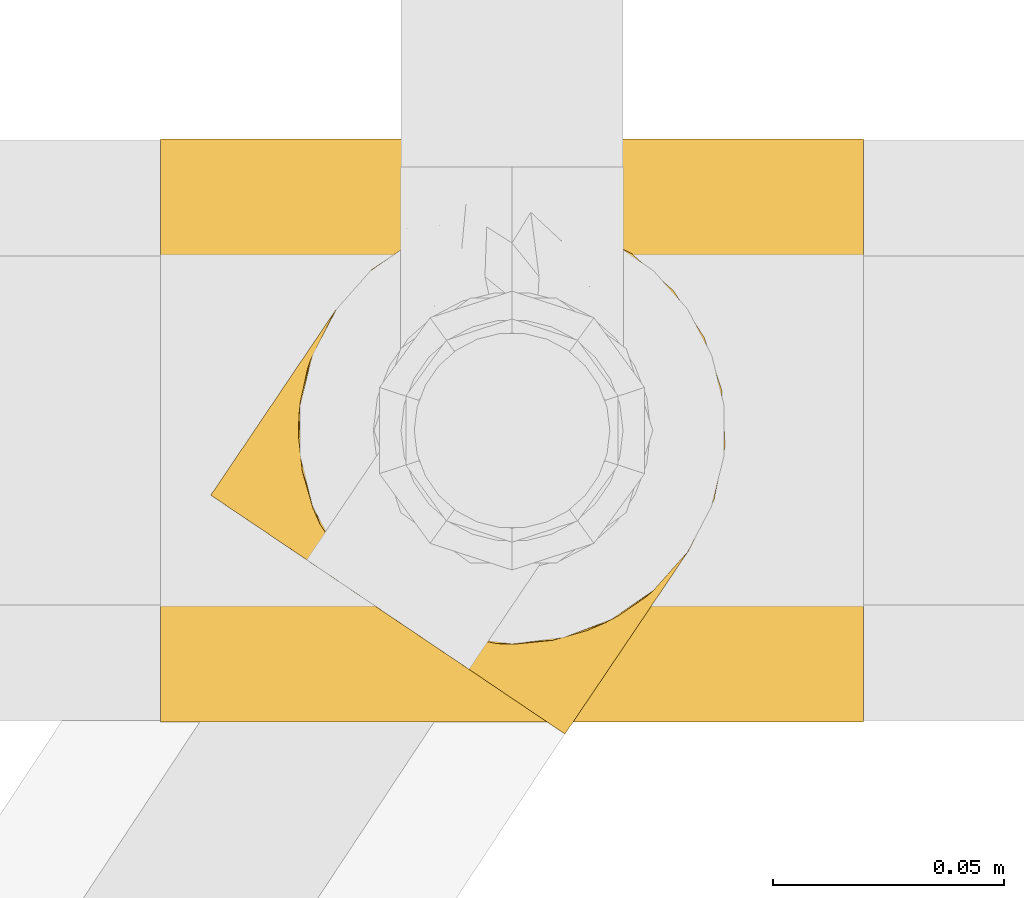
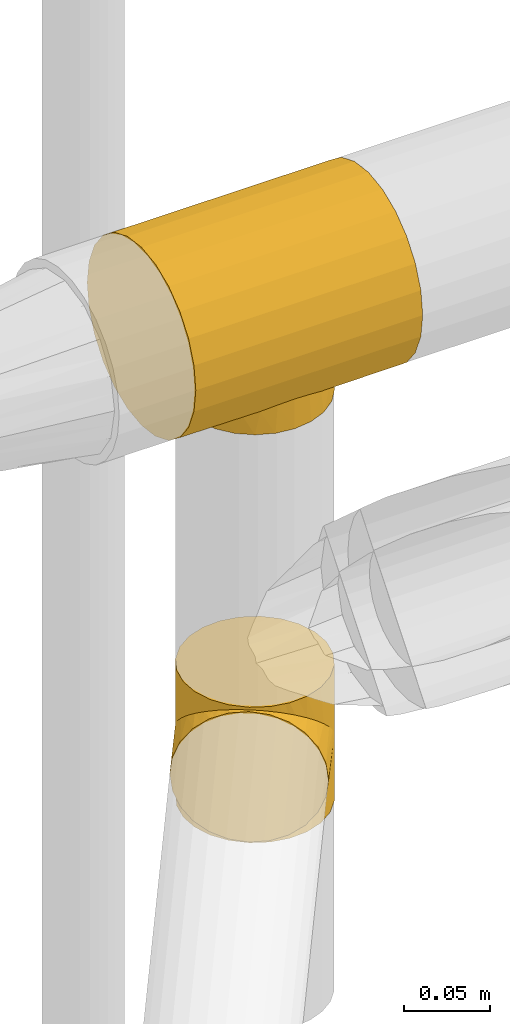
# One storey, part 390 of 827: 2 coverings.
"""IFC2X3 building model written with IfcOpenShell, lengths in millimetres."""

from ifc_helpers import new_model, entity, si_unit, converted_unit, derived_unit, direction, frame, origin, place, context, subcontext, project, spatial, faceted_brep, element, save


model = new_model("IFC2X3")

# Units and contexts
model_context = context("Model", 3, precision=0.01, world=origin(), true_north=direction((6.12303176911189e-17, 1.0)))
body_context = subcontext(model_context, "Body", "Model", "MODEL_VIEW")
ifc_project = project(units=[si_unit("LENGTHUNIT", "METRE", prefix="MILLI"), si_unit("AREAUNIT", "SQUARE_METRE"), si_unit("VOLUMEUNIT", "CUBIC_METRE"), converted_unit("PLANEANGLEUNIT", "DEGREE", entity("IfcRatioMeasure", 0.0174532925199433), si_unit("PLANEANGLEUNIT", "RADIAN"), dimensions=[0, 0, 0, 0, 0, 0, 0]), si_unit("MASSUNIT", "GRAM", prefix="KILO"), derived_unit("MASSDENSITYUNIT", [(si_unit("MASSUNIT", "GRAM", prefix="KILO"), 1), (si_unit("LENGTHUNIT", "METRE"), -3)]), derived_unit("MOMENTOFINERTIAUNIT", [(si_unit("LENGTHUNIT", "METRE"), 4)]), si_unit("TIMEUNIT", "SECOND"), si_unit("FREQUENCYUNIT", "HERTZ"), si_unit("THERMODYNAMICTEMPERATUREUNIT", "DEGREE_CELSIUS"), derived_unit("THERMALTRANSMITTANCEUNIT", [(si_unit("MASSUNIT", "GRAM", prefix="KILO"), 1), (si_unit("THERMODYNAMICTEMPERATUREUNIT", "KELVIN"), -1), (si_unit("TIMEUNIT", "SECOND"), -3)]), derived_unit("VOLUMETRICFLOWRATEUNIT", [(si_unit("LENGTHUNIT", "METRE"), 3), (si_unit("TIMEUNIT", "SECOND"), -1)]), derived_unit("MASSFLOWRATEUNIT", [(si_unit("MASSUNIT", "GRAM", prefix="KILO"), 1), (si_unit("TIMEUNIT", "SECOND"), -1)]), derived_unit("ROTATIONALFREQUENCYUNIT", [(si_unit("TIMEUNIT", "SECOND"), -1)]), si_unit("ELECTRICCURRENTUNIT", "AMPERE"), si_unit("ELECTRICVOLTAGEUNIT", "VOLT"), si_unit("POWERUNIT", "WATT"), si_unit("FORCEUNIT", "NEWTON", prefix="KILO"), si_unit("ILLUMINANCEUNIT", "LUX"), si_unit("LUMINOUSFLUXUNIT", "LUMEN"), si_unit("LUMINOUSINTENSITYUNIT", "CANDELA"), derived_unit("USERDEFINED", [(si_unit("MASSUNIT", "GRAM", prefix="KILO"), -1), (si_unit("LENGTHUNIT", "METRE"), -2), (si_unit("TIMEUNIT", "SECOND"), 3), (si_unit("LUMINOUSFLUXUNIT", "LUMEN"), 1)]), derived_unit("LINEARVELOCITYUNIT", [(si_unit("LENGTHUNIT", "METRE"), 1), (si_unit("TIMEUNIT", "SECOND"), -1)]), si_unit("PRESSUREUNIT", "PASCAL"), derived_unit("USERDEFINED", [(si_unit("LENGTHUNIT", "METRE"), -2), (si_unit("MASSUNIT", "GRAM", prefix="KILO"), 1), (si_unit("TIMEUNIT", "SECOND"), -2)]), derived_unit("LINEARFORCEUNIT", [(si_unit("MASSUNIT", "GRAM", prefix="KILO"), 1), (si_unit("LENGTHUNIT", "METRE"), 1), (si_unit("TIMEUNIT", "SECOND"), -2), (si_unit("LENGTHUNIT", "METRE"), -1)]), derived_unit("PLANARFORCEUNIT", [(si_unit("MASSUNIT", "GRAM", prefix="KILO"), 1), (si_unit("LENGTHUNIT", "METRE"), 1), (si_unit("TIMEUNIT", "SECOND"), -2), (si_unit("LENGTHUNIT", "METRE"), -2)])], contexts=[model_context])

# Site, building, storey
site_placement = place(None, origin())
site = spatial("IfcSite", under=ifc_project, at=site_placement, CompositionType="ELEMENT")
building_placement = place(site_placement, origin())
building = spatial("IfcBuilding", under=site, at=building_placement, CompositionType="ELEMENT")
storey_placement = place(building_placement, frame((0.0, 0.0, 28200.0)))
storey = spatial("IfcBuildingStorey", under=building, at=storey_placement, Name="08", CompositionType="ELEMENT", Elevation=28200.0)

# Coverings
covering_1_placement = place(storey_placement, frame((48216.02, 14171.03, 2540.35)))
element("IfcCovering", 1, at=covering_1_placement, inside=storey, Name=":ADSK_", ObjectType=":ADSK_", PredefinedType="INSULATION", context=body_context, shape_type="Brep", body=[
    faceted_brep([(152.0, 96.17, 119.25), (152.0, 80.96, 125.55), (152.0, 64.65, 127.7), (152.0, 48.33, 125.55), (152.0, 33.12, 119.25), (152.0, 20.06, 109.23), (152.0, 10.04, 96.17), (152.0, 3.74, 80.96), (152.0, 1.6, 64.65), (152.0, 3.74, 48.33), (152.0, 10.04, 33.12), (152.0, 20.06, 20.06), (152.0, 26.59, 15.05), (152.0, 33.12, 10.04), (152.0, 40.72, 6.89), (152.0, 48.33, 3.74), (152.0, 56.49, 2.67), (152.0, 64.65, 1.6), (152.0, 72.8, 2.67), (152.0, 80.96, 3.74), (152.0, 88.57, 6.89), (152.0, 96.17, 10.04), (152.0, 102.7, 15.05), (152.0, 109.23, 20.06), (152.0, 119.25, 33.12), (152.0, 125.55, 48.33), (152.0, 127.7, 64.65), (152.0, 125.55, 80.96), (152.0, 119.25, 96.17), (152.0, 109.23, 109.23), (0.0, 1.6, 64.65), (0.0, 3.74, 80.96), (0.0, 10.04, 96.17), (0.0, 20.06, 109.23), (0.0, 33.12, 119.25), (0.0, 48.33, 125.55), (0.0, 64.65, 127.7), (0.0, 80.96, 125.55), (0.0, 96.17, 119.25), (0.0, 109.23, 109.23), (0.0, 119.25, 96.17), (0.0, 125.55, 80.96), (0.0, 127.7, 64.65), (0.0, 125.55, 48.33), (0.0, 119.25, 33.12), (0.0, 109.23, 20.06), (0.0, 102.7, 15.05), (0.0, 96.17, 10.04), (0.0, 88.57, 6.89), (0.0, 80.96, 3.74), (0.0, 72.8, 2.67), (0.0, 64.65, 1.6), (0.0, 56.49, 2.67), (0.0, 48.33, 3.74), (0.0, 40.72, 6.89), (0.0, 33.12, 10.04), (0.0, 26.59, 15.05), (0.0, 20.06, 20.06), (0.0, 10.04, 33.12), (0.0, 3.74, 48.33), (55.66, 23.17, 17.16), (47.22, 28.5, 12.98), (117.36, 44.06, 5.05), (65.36, 19.69, 20.44), (76.0, 18.45, 21.74), (86.64, 19.69, 20.44), (121.57, 59.29, 2.05), (121.73, 60.63, 1.94), (121.89, 61.97, 1.82), (122.04, 63.31, 1.71), (122.2, 64.65, 1.6), (29.8, 64.65, 1.6), (29.96, 63.31, 1.71), (30.11, 61.97, 1.82), (30.27, 60.63, 1.94), (30.43, 59.29, 2.05), (96.34, 23.17, 17.16), (104.78, 28.5, 12.98), (34.64, 44.06, 5.05), (37.39, 39.78, 6.89), (40.15, 35.5, 8.73), (119.15, 49.0, 3.78), (120.05, 51.47, 3.15), (120.94, 53.94, 2.51), (31.06, 53.94, 2.51), (30.74, 56.62, 2.28), (31.95, 51.47, 3.15), (32.85, 49.0, 3.78), (111.85, 35.5, 8.73), (114.61, 39.78, 6.89), (121.26, 56.62, 2.28), (30.43, 70.0, 2.05), (31.06, 75.35, 2.51), (40.15, 93.79, 8.73), (37.39, 89.51, 6.89), (34.64, 85.23, 5.05), (32.85, 80.29, 3.78), (31.95, 77.82, 3.15), (30.74, 72.67, 2.28), (121.57, 70.0, 2.05), (121.26, 72.67, 2.28), (120.94, 75.35, 2.51), (122.04, 65.98, 1.71), (121.89, 67.32, 1.82), (121.73, 68.66, 1.94), (30.27, 68.66, 1.94), (30.11, 67.32, 1.82), (29.96, 65.98, 1.71), (111.85, 93.79, 8.73), (117.36, 85.23, 5.05), (104.78, 100.79, 12.98), (120.05, 77.82, 3.15), (119.15, 80.29, 3.78), (47.22, 100.79, 12.98), (55.66, 106.13, 17.16), (65.36, 109.6, 20.44), (76.0, 110.85, 21.74), (96.34, 106.13, 17.16), (86.64, 109.6, 20.44), (114.61, 89.51, 6.89), (76.0, 18.45, 0.65), (64.04, 20.02, 0.65), (52.9, 24.63, 0.65), (43.33, 31.98, 0.65), (35.99, 41.55, 0.65), (33.68, 47.12, 0.65), (32.53, 49.9, 0.65), (31.37, 52.69, 0.65), (31.18, 54.18, 0.65), (30.98, 55.68, 0.65), (30.78, 57.17, 0.65), (30.59, 58.67, 0.65), (30.39, 60.16, 0.65), (30.19, 61.66, 0.65), (30.0, 63.15, 0.65), (29.8, 64.65, 0.65), (30.0, 66.14, 0.65), (30.19, 67.63, 0.65), (30.39, 69.13, 0.65), (30.59, 70.62, 0.65), (30.78, 72.12, 0.65), (30.98, 73.61, 0.65), (31.18, 75.11, 0.65), (31.37, 76.6, 0.65), (32.53, 79.39, 0.65), (33.68, 82.17, 0.65), (35.99, 87.75, 0.65), (43.33, 97.31, 0.65), (52.9, 104.66, 0.65), (64.04, 109.27, 0.65), (76.0, 110.85, 0.65), (87.96, 109.27, 0.65), (99.1, 104.66, 0.65), (108.67, 97.31, 0.65), (116.01, 87.75, 0.65), (118.32, 82.17, 0.65), (119.47, 79.39, 0.65), (120.63, 76.6, 0.65), (120.82, 75.11, 0.65), (121.02, 73.61, 0.65), (121.22, 72.12, 0.65), (121.41, 70.62, 0.65), (121.61, 69.13, 0.65), (121.81, 67.63, 0.65), (122.0, 66.14, 0.65), (122.2, 64.65, 0.65), (122.0, 63.15, 0.65), (121.81, 61.66, 0.65), (121.61, 60.16, 0.65), (121.41, 58.67, 0.65), (121.22, 57.17, 0.65), (121.02, 55.68, 0.65), (120.82, 54.18, 0.65), (120.63, 52.69, 0.65), (119.47, 49.9, 0.65), (118.32, 47.12, 0.65), (116.01, 41.55, 0.65), (108.67, 31.98, 0.65), (99.1, 24.63, 0.65), (87.96, 20.02, 0.65)], [[[0, 1, 2, 3, 4, 5, 6, 7, 8, 9, 10, 11, 12, 13, 14, 15, 16, 17, 18, 19, 20, 21, 22, 23, 24, 25, 26, 27, 28, 29]], [[30, 31, 32, 33, 34, 35, 36, 37, 38, 39, 40, 41, 42, 43, 44, 45, 46, 47, 48, 49, 50, 51, 52, 53, 54, 55, 56, 57, 58, 59]], [[34, 33, 5, 4]], [[2, 36, 35, 3]], [[4, 3, 35, 34]], [[6, 32, 31, 7]], [[7, 31, 30, 8]], [[5, 33, 32, 6]], [[59, 9, 8, 30]], [[58, 10, 9, 59]], [[56, 60, 57]], [[61, 56, 55]], [[62, 15, 14]], [[60, 63, 57]], [[60, 56, 61]], [[58, 57, 64]], [[57, 63, 64]], [[64, 65, 11]], [[17, 66, 67, 68, 69, 70]], [[51, 71, 72, 73, 74, 75]], [[12, 76, 77]], [[76, 11, 65]], [[77, 13, 12]], [[64, 11, 10]], [[64, 10, 58]], [[54, 78, 79, 80]], [[54, 80, 55]], [[78, 54, 53]], [[15, 62, 81, 82, 83]], [[84, 53, 52]], [[51, 75, 52]], [[52, 75, 85, 84]], [[53, 84, 86, 87, 78]], [[77, 88, 13]], [[88, 14, 13]], [[14, 88, 89, 62]], [[16, 83, 90, 66]], [[12, 11, 76]], [[17, 16, 66]], [[16, 15, 83]], [[80, 61, 55]], [[50, 91, 51]], [[92, 50, 49]], [[47, 93, 48]], [[48, 93, 94, 95]], [[95, 49, 48]], [[49, 95, 96, 97, 92]], [[50, 92, 98, 91]], [[18, 99, 100, 101]], [[17, 70, 102, 103, 104, 99]], [[51, 91, 105, 106, 107, 71]], [[108, 21, 20]], [[17, 99, 18]], [[20, 19, 109]], [[21, 108, 110]], [[109, 19, 101, 111, 112]], [[113, 47, 46]], [[113, 93, 47]], [[46, 114, 113]], [[114, 46, 45]], [[114, 45, 115]], [[24, 44, 43, 25]], [[44, 116, 45]], [[45, 116, 115]], [[43, 42, 26, 25]], [[101, 19, 18]], [[117, 118, 23]], [[20, 109, 119, 108]], [[110, 22, 21]], [[22, 117, 23]], [[118, 116, 23]], [[116, 24, 23]], [[116, 44, 24]], [[117, 22, 110]], [[27, 41, 40, 28]], [[28, 40, 39, 29]], [[42, 41, 27, 26]], [[0, 38, 37, 1]], [[1, 37, 36, 2]], [[29, 39, 38, 0]], [[120, 121, 122, 123, 124, 125, 126, 127, 128, 129, 130, 131, 132, 133, 134, 135, 136, 137, 138, 139, 140, 141, 142, 143, 144, 145, 146, 147, 148, 149, 150, 151, 152, 153, 154, 155, 156, 157, 158, 159, 160, 161, 162, 163, 164, 165, 166, 167, 168, 169, 170, 171, 172, 173, 174, 175, 176, 177, 178, 179]], [[84, 129, 128, 127]], [[132, 75, 74]], [[74, 133, 132]], [[78, 125, 124]], [[73, 134, 133]], [[132, 131, 75]], [[127, 86, 84]], [[79, 78, 124]], [[86, 126, 87]], [[123, 79, 124]], [[123, 80, 79]], [[87, 126, 125]], [[61, 123, 122]], [[85, 131, 130, 129]], [[122, 121, 60]], [[129, 84, 85]], [[72, 135, 134]], [[120, 63, 121]], [[125, 78, 87]], [[61, 122, 60]], [[86, 127, 126]], [[63, 60, 121]], [[64, 63, 120]], [[131, 85, 75]], [[123, 61, 80]], [[133, 74, 73]], [[135, 72, 71]], [[134, 73, 72]], [[65, 120, 179]], [[69, 165, 70]], [[90, 171, 170, 169]], [[76, 179, 178]], [[173, 83, 82]], [[64, 120, 65]], [[176, 62, 89]], [[65, 179, 76]], [[178, 77, 76]], [[83, 173, 172, 171]], [[178, 177, 77]], [[167, 67, 168]], [[177, 176, 89]], [[167, 68, 67]], [[175, 174, 81]], [[81, 174, 82]], [[67, 66, 168]], [[169, 66, 90]], [[88, 177, 89]], [[62, 176, 175]], [[171, 90, 83]], [[175, 81, 62]], [[82, 174, 173]], [[166, 69, 68]], [[177, 88, 77]], [[66, 169, 168]], [[68, 167, 166]], [[165, 69, 166]], [[101, 159, 158, 157]], [[162, 99, 104]], [[104, 163, 162]], [[109, 155, 154]], [[103, 164, 163]], [[162, 161, 99]], [[157, 111, 101]], [[119, 109, 154]], [[111, 156, 112]], [[153, 119, 154]], [[153, 108, 119]], [[112, 156, 155]], [[110, 153, 152]], [[100, 161, 160, 159]], [[152, 151, 117]], [[159, 101, 100]], [[102, 165, 164]], [[150, 118, 151]], [[155, 109, 112]], [[110, 152, 117]], [[111, 157, 156]], [[118, 117, 151]], [[116, 118, 150]], [[161, 100, 99]], [[153, 110, 108]], [[163, 104, 103]], [[165, 102, 70]], [[164, 103, 102]], [[115, 150, 149]], [[107, 135, 71]], [[98, 141, 140, 139]], [[114, 149, 148]], [[143, 92, 97]], [[116, 150, 115]], [[146, 95, 94]], [[115, 149, 114]], [[148, 113, 114]], [[92, 143, 142, 141]], [[148, 147, 113]], [[137, 105, 138]], [[147, 146, 94]], [[137, 106, 105]], [[145, 144, 96]], [[96, 144, 97]], [[105, 91, 138]], [[139, 91, 98]], [[93, 147, 94]], [[95, 146, 145]], [[141, 98, 92]], [[145, 96, 95]], [[97, 144, 143]], [[136, 107, 106]], [[147, 93, 113]], [[91, 139, 138]], [[106, 137, 136]], [[135, 107, 136]]]),
])
covering_2_placement = place(storey_placement, frame((48225.28, 14168.45, 2252.0)))
element("IfcCovering", 2, at=covering_2_placement, inside=storey, Name=":ADSK_", ObjectType=":ADSK_", PredefinedType="INSULATION", context=body_context, shape_type="Brep", body=[
    faceted_brep([(54.0, 23.06, 4.27), (51.7, 23.54, 0.0), (54.65, 22.94, 0.0), (44.95, 26.9, 0.0), (46.3, 26.23, 0.0), (45.2, 26.64, 2.31), (51.75, 23.71, 3.55), (50.63, 24.03, 3.19), (57.61, 22.34, 0.0), (58.5, 21.76, 5.7), (56.25, 22.41, 4.98), (49.5, 24.36, 2.83), (49.0, 24.89, 0.0), (50.35, 24.21, 0.0), (60.56, 21.74, 0.0), (63.52, 21.14, 0.0), (62.88, 21.4, 7.85), (67.27, 21.03, 10.0), (69.53, 21.5, 0.0), (75.47, 21.86, 15.27), (43.05, 27.78, 2.06), (42.25, 28.25, 0.0), (42.93, 27.91, 0.0), (43.6, 27.58, 0.0), (75.55, 21.87, 0.0), (82.97, 23.97, 21.21), (86.99, 25.7, 0.0), (47.35, 25.5, 2.57), (46.28, 26.07, 2.44), (89.69, 27.13, 27.6), (97.05, 32.36, 0.0), (48.43, 24.93, 2.7), (47.65, 25.56, 0.0), (100.75, 35.95, 41.09), (105.04, 41.39, 0.0), (95.62, 31.17, 34.26), (105.04, 41.39, 48.0), (100.75, 35.95, 54.91), (105.04, 41.39, 96.0), (41.98, 28.35, 1.93), (40.9, 28.92, 0.0), (44.13, 27.21, 2.18), (44.28, 27.24, 0.0), (40.9, 28.92, 1.8), (41.98, 28.35, 94.07), (40.9, 28.92, 96.0), (40.9, 28.92, 94.2), (25.0, 87.04, 41.09), (28.44, 93.06, 0.0), (23.06, 82.27, 0.0), (25.69, 46.48, 7.85), (26.88, 44.46, 0.0), (27.68, 42.55, 5.7), (20.65, 70.45, 0.0), (20.97, 73.49, 27.6), (20.55, 66.08, 21.22), (21.39, 58.41, 0.0), (25.21, 46.97, 0.0), (31.87, 36.91, 0.0), (32.74, 36.1, 3.18), (32.01, 37.02, 3.54), (30.57, 38.87, 4.26), (28.44, 93.06, 48.0), (25.0, 87.04, 54.91), (28.44, 93.06, 96.0), (33.46, 35.18, 2.82), (33.0, 35.91, 0.0), (34.13, 34.92, 0.0), (22.49, 80.5, 34.26), (38.08, 31.42, 0.0), (38.65, 30.92, 0.0), (38.11, 31.27, 2.18), (37.52, 31.92, 0.0), (23.7, 50.41, 10.0), (23.3, 52.69, 0.0), (30.21, 39.43, 0.0), (29.12, 40.71, 4.98), (28.54, 41.94, 0.0), (39.77, 29.92, 0.0), (39.97, 29.7, 1.93), (39.04, 30.49, 2.06), (37.18, 32.05, 2.31), (35.26, 33.92, 0.0), (36.39, 32.92, 0.0), (35.32, 33.61, 2.57), (21.4, 58.33, 15.28), (34.39, 34.4, 2.7), (36.25, 32.83, 2.44), (39.97, 29.7, 94.07), (39.21, 30.42, 0.0), (108.26, 87.48, 96.0), (101.61, 97.53, 96.0), (92.57, 105.53, 96.0), (81.78, 110.91, 96.0), (69.96, 113.31, 96.0), (57.92, 112.57, 96.0), (46.49, 108.75, 96.0), (36.43, 102.09, 96.0), (23.06, 82.27, 96.0), (20.65, 70.45, 96.0), (21.39, 58.41, 96.0), (23.3, 52.69, 96.0), (25.21, 46.97, 96.0), (26.88, 44.46, 96.0), (28.54, 41.94, 96.0), (30.21, 39.43, 96.0), (31.87, 36.91, 96.0), (33.0, 35.91, 96.0), (34.13, 34.92, 96.0), (35.26, 33.92, 96.0), (36.39, 32.92, 96.0), (37.52, 31.92, 96.0), (38.08, 31.42, 96.0), (38.65, 30.92, 96.0), (39.21, 30.42, 96.0), (39.77, 29.92, 96.0), (42.25, 28.25, 96.0), (42.93, 27.91, 96.0), (43.6, 27.58, 96.0), (44.28, 27.24, 96.0), (44.95, 26.9, 96.0), (46.3, 26.23, 96.0), (47.65, 25.56, 96.0), (49.0, 24.89, 96.0), (50.35, 24.21, 96.0), (51.7, 23.54, 96.0), (54.65, 22.94, 96.0), (57.61, 22.34, 96.0), (60.56, 21.74, 96.0), (63.52, 21.14, 96.0), (69.53, 21.5, 96.0), (75.55, 21.87, 96.0), (86.99, 25.7, 96.0), (97.05, 32.36, 96.0), (110.42, 52.18, 96.0), (112.83, 64.0, 96.0), (112.09, 76.04, 96.0), (36.43, 102.09, 0.0), (46.49, 108.75, 0.0), (57.92, 112.57, 0.0), (69.96, 113.31, 0.0), (81.78, 110.91, 0.0), (92.57, 105.53, 0.0), (101.61, 97.53, 0.0), (108.26, 87.48, 0.0), (112.09, 76.04, 0.0), (112.83, 64.0, 0.0), (110.42, 52.18, 0.0), (30.57, 38.87, 91.74), (32.01, 37.02, 92.46), (32.74, 36.1, 92.82), (22.49, 80.5, 61.74), (20.97, 73.49, 68.4), (27.68, 42.55, 90.3), (34.39, 34.4, 93.3), (35.32, 33.61, 93.43), (20.55, 66.08, 74.78), (23.7, 50.41, 86.0), (25.69, 46.48, 88.15), (21.4, 58.33, 80.72), (29.12, 40.71, 91.02), (33.46, 35.18, 93.18), (39.04, 30.49, 93.94), (36.25, 32.83, 93.56), (37.18, 32.05, 93.69), (38.11, 31.27, 93.82), (58.5, 21.76, 90.3), (56.25, 22.41, 91.02), (67.27, 21.03, 86.0), (47.35, 25.5, 93.43), (75.47, 21.86, 80.73), (62.88, 21.4, 88.15), (48.43, 24.93, 93.3), (49.5, 24.36, 93.17), (44.13, 27.21, 93.82), (45.2, 26.64, 93.69), (54.0, 23.06, 91.73), (50.63, 24.03, 92.81), (51.75, 23.71, 92.45), (89.69, 27.13, 68.4), (95.62, 31.17, 61.74), (82.97, 23.97, 74.79), (46.28, 26.07, 93.56), (43.05, 27.78, 93.94), (1.6, 53.26, 48.0), (2.9, 52.38, 36.04), (6.73, 49.8, 24.9), (12.81, 45.7, 15.33), (16.78, 43.02, 11.66), (20.75, 40.35, 7.99), (23.06, 38.79, 6.84), (25.36, 37.23, 5.68), (27.67, 35.67, 4.53), (29.98, 34.12, 3.37), (31.22, 33.28, 3.18), (32.46, 32.44, 2.98), (33.7, 31.61, 2.78), (34.94, 30.77, 2.59), (36.18, 29.94, 2.39), (36.8, 29.52, 2.29), (37.42, 29.1, 2.19), (38.04, 28.68, 2.1), (38.66, 28.27, 2.0), (39.9, 27.43, 1.8), (41.14, 26.59, 2.0), (41.76, 26.18, 2.1), (42.38, 25.76, 2.19), (42.99, 25.34, 2.29), (43.61, 24.92, 2.39), (44.85, 24.09, 2.59), (46.09, 23.25, 2.78), (47.33, 22.42, 2.98), (48.57, 21.58, 3.18), (49.81, 20.74, 3.37), (52.12, 19.19, 4.53), (54.43, 17.63, 5.68), (56.74, 16.07, 6.84), (59.05, 14.51, 7.99), (63.01, 11.84, 11.66), (66.98, 9.16, 15.33), (73.07, 5.06, 24.9), (76.89, 2.48, 36.04), (78.2, 1.6, 48.0), (76.89, 2.48, 59.96), (73.07, 5.06, 71.1), (66.98, 9.16, 80.67), (63.01, 11.84, 84.34), (59.05, 14.51, 88.01), (56.74, 16.07, 89.16), (54.43, 17.63, 90.32), (52.12, 19.19, 91.47), (49.81, 20.74, 92.63), (48.57, 21.58, 92.82), (47.33, 22.42, 93.02), (46.09, 23.25, 93.22), (44.85, 24.09, 93.41), (43.61, 24.92, 93.61), (42.99, 25.34, 93.71), (42.38, 25.76, 93.81), (41.76, 26.18, 93.9), (41.14, 26.59, 94.0), (39.9, 27.43, 94.2), (38.66, 28.27, 94.0), (38.04, 28.68, 93.9), (37.42, 29.1, 93.81), (36.8, 29.52, 93.71), (36.18, 29.94, 93.61), (34.94, 30.77, 93.41), (33.7, 31.61, 93.22), (32.46, 32.44, 93.02), (31.22, 33.28, 92.82), (29.98, 34.12, 92.63), (27.67, 35.67, 91.47), (25.36, 37.23, 90.32), (23.06, 38.79, 89.16), (20.75, 40.35, 88.01), (16.78, 43.02, 84.34), (12.81, 45.7, 80.67), (6.73, 49.8, 71.1), (2.9, 52.38, 59.96)], [[[0, 1, 2]], [[3, 4, 5]], [[1, 0, 6, 7]], [[8, 9, 10]], [[11, 12, 13]], [[14, 15, 16]], [[2, 10, 0]], [[11, 13, 7]], [[17, 15, 18]], [[19, 17, 18]], [[14, 16, 9]], [[20, 21, 22, 23]], [[18, 24, 19]], [[15, 17, 16]], [[25, 24, 26]], [[4, 27, 28, 5]], [[29, 26, 30]], [[31, 32, 12]], [[12, 11, 31]], [[33, 30, 34]], [[32, 31, 27]], [[29, 25, 26]], [[33, 35, 30]], [[36, 33, 34]], [[37, 36, 38]], [[9, 8, 14]], [[29, 30, 35]], [[10, 2, 8]], [[1, 7, 13]], [[24, 25, 19]], [[27, 4, 32]], [[39, 40, 21]], [[41, 3, 5]], [[23, 41, 20]], [[3, 41, 23, 42]], [[40, 39, 43]], [[44, 45, 46]], [[21, 20, 39]], [[47, 48, 49]], [[50, 51, 52]], [[49, 53, 54]], [[55, 53, 56]], [[51, 50, 57]], [[55, 54, 53]], [[58, 59, 60, 61]], [[47, 62, 48]], [[62, 63, 64]], [[65, 66, 67]], [[54, 68, 49]], [[47, 49, 68]], [[66, 65, 59]], [[59, 58, 66]], [[69, 70, 71, 72]], [[73, 74, 57]], [[75, 76, 77]], [[75, 58, 61]], [[78, 79, 80]], [[76, 75, 61]], [[81, 72, 71]], [[82, 83, 84]], [[85, 56, 74]], [[85, 74, 73]], [[52, 77, 76]], [[67, 86, 65]], [[52, 51, 77]], [[73, 57, 50]], [[82, 86, 67]], [[56, 85, 55]], [[83, 81, 87, 84]], [[81, 83, 72]], [[86, 82, 84]], [[79, 40, 43]], [[45, 88, 46]], [[70, 80, 71]], [[80, 70, 89, 78]], [[40, 79, 78]], [[90, 91, 92, 93, 94, 95, 96, 97, 64, 98, 99, 100, 101, 102, 103, 104, 105, 106, 107, 108, 109, 110, 111, 112, 113, 114, 115, 45, 116, 117, 118, 119, 120, 121, 122, 123, 124, 125, 126, 127, 128, 129, 130, 131, 132, 133, 38, 134, 135, 136]], [[48, 137, 138, 139, 140, 141, 142, 143, 144, 145, 146, 147, 34, 30, 26, 24, 18, 15, 14, 8, 2, 1, 13, 12, 32, 4, 3, 42, 23, 22, 21, 40, 78, 89, 70, 69, 72, 83, 82, 67, 66, 58, 75, 77, 51, 57, 74, 56, 53, 49]], [[140, 139, 95, 94]], [[92, 142, 141, 93]], [[141, 140, 94, 93]], [[96, 138, 137, 97]], [[48, 62, 64, 97, 137]], [[95, 139, 138, 96]], [[106, 148, 149, 150]], [[151, 152, 98]], [[153, 104, 103]], [[148, 106, 105]], [[63, 151, 98]], [[109, 154, 155]], [[64, 63, 98]], [[99, 156, 100]], [[99, 98, 152]], [[156, 99, 152]], [[102, 157, 158]], [[106, 150, 107]], [[155, 110, 109]], [[157, 101, 159]], [[105, 160, 148]], [[161, 107, 150]], [[162, 115, 114, 113]], [[157, 102, 101]], [[153, 103, 158]], [[104, 153, 160]], [[159, 101, 100]], [[102, 158, 103]], [[108, 161, 154]], [[110, 155, 163, 164]], [[164, 111, 110]], [[161, 108, 107]], [[160, 105, 104]], [[159, 100, 156]], [[154, 109, 108]], [[88, 45, 115]], [[165, 111, 164]], [[113, 165, 162]], [[111, 165, 113, 112]], [[115, 162, 88]], [[166, 127, 167]], [[166, 128, 127]], [[129, 168, 130]], [[122, 121, 169]], [[170, 130, 168]], [[171, 168, 129]], [[123, 172, 173]], [[119, 118, 174, 120]], [[128, 171, 129]], [[174, 175, 120]], [[126, 125, 176]], [[171, 128, 166]], [[170, 131, 130]], [[125, 177, 178, 176]], [[179, 180, 133]], [[173, 124, 123]], [[177, 125, 124]], [[180, 37, 133]], [[131, 181, 132]], [[181, 131, 170]], [[179, 132, 181]], [[179, 133, 132]], [[121, 175, 182, 169]], [[167, 126, 176]], [[37, 38, 133]], [[126, 167, 127]], [[122, 172, 123]], [[124, 173, 177]], [[116, 44, 183]], [[175, 121, 120]], [[172, 122, 169]], [[118, 183, 174]], [[183, 118, 117, 116]], [[45, 44, 116]], [[36, 34, 147, 134, 38]], [[134, 147, 146, 135]], [[146, 145, 136, 135]], [[136, 145, 144, 90]], [[90, 144, 143, 91]], [[91, 143, 142, 92]], [[184, 185, 186, 187, 188, 189, 190, 191, 192, 193, 194, 195, 196, 197, 198, 199, 200, 201, 202, 203, 204, 205, 206, 207, 208, 209, 210, 211, 212, 213, 214, 215, 216, 217, 218, 219, 220, 221, 222, 223, 224, 225, 226, 227, 228, 229, 230, 231, 232, 233, 234, 235, 236, 237, 238, 239, 240, 241, 242, 243, 244, 245, 246, 247, 248, 249, 250, 251, 252, 253, 254, 255, 256, 257, 258, 259]], [[86, 196, 195]], [[198, 197, 81]], [[193, 61, 60, 59]], [[52, 191, 190]], [[61, 193, 192]], [[190, 189, 50]], [[192, 76, 61]], [[65, 194, 59]], [[73, 189, 188]], [[85, 73, 188]], [[190, 50, 52]], [[80, 202, 201, 200]], [[188, 187, 85]], [[189, 73, 50]], [[55, 187, 186]], [[76, 192, 191]], [[54, 186, 185]], [[193, 59, 194]], [[47, 185, 184]], [[191, 52, 76]], [[54, 55, 186]], [[197, 84, 87, 81]], [[47, 68, 185]], [[62, 47, 184]], [[65, 195, 194]], [[54, 185, 68]], [[196, 86, 84]], [[187, 55, 85]], [[84, 197, 196]], [[195, 65, 86]], [[79, 203, 202]], [[71, 198, 81]], [[200, 71, 80]], [[198, 71, 200, 199]], [[203, 79, 43]], [[202, 80, 79]], [[63, 184, 259]], [[158, 254, 153]], [[259, 258, 152]], [[156, 258, 257]], [[254, 158, 255]], [[156, 152, 258]], [[251, 150, 149, 148]], [[63, 62, 184]], [[161, 250, 249]], [[152, 151, 259]], [[63, 259, 151]], [[250, 161, 150]], [[150, 251, 250]], [[245, 244, 165, 246]], [[157, 256, 255]], [[252, 160, 253]], [[252, 251, 148]], [[242, 88, 162]], [[160, 252, 148]], [[164, 246, 165]], [[248, 247, 155]], [[159, 257, 256]], [[159, 256, 157]], [[153, 253, 160]], [[249, 154, 161]], [[153, 254, 253]], [[157, 255, 158]], [[248, 154, 249]], [[257, 159, 156]], [[247, 164, 163, 155]], [[164, 247, 246]], [[154, 248, 155]], [[88, 241, 46]], [[244, 162, 165]], [[162, 244, 243, 242]], [[241, 88, 242]], [[176, 231, 230]], [[236, 235, 175]], [[231, 176, 178, 177]], [[229, 166, 167]], [[173, 233, 232]], [[228, 227, 171]], [[230, 167, 176]], [[173, 232, 177]], [[168, 227, 226]], [[170, 168, 226]], [[228, 171, 166]], [[183, 240, 239, 238]], [[226, 225, 170]], [[227, 168, 171]], [[181, 225, 224]], [[235, 169, 182, 175]], [[179, 224, 223]], [[172, 234, 233]], [[233, 173, 172]], [[37, 223, 222]], [[234, 172, 169]], [[179, 181, 224]], [[37, 180, 223]], [[36, 37, 222]], [[166, 229, 228]], [[179, 223, 180]], [[167, 230, 229]], [[231, 177, 232]], [[225, 181, 170]], [[169, 235, 234]], [[44, 241, 240]], [[174, 236, 175]], [[238, 174, 183]], [[236, 174, 238, 237]], [[241, 44, 46]], [[240, 183, 44]], [[33, 222, 221]], [[209, 5, 28, 27]], [[221, 220, 29]], [[25, 220, 219]], [[210, 31, 211]], [[25, 29, 220]], [[16, 216, 9]], [[33, 36, 222]], [[7, 213, 212]], [[29, 35, 221]], [[33, 221, 35]], [[11, 212, 211]], [[216, 16, 217]], [[207, 206, 41, 208]], [[17, 218, 217]], [[204, 39, 20]], [[214, 213, 0]], [[10, 214, 0]], [[212, 11, 7]], [[5, 208, 41]], [[210, 209, 27]], [[19, 219, 218]], [[19, 218, 17]], [[9, 215, 10]], [[211, 31, 11]], [[9, 216, 215]], [[17, 217, 16]], [[213, 7, 6, 0]], [[219, 19, 25]], [[214, 10, 215]], [[5, 209, 208]], [[31, 210, 27]], [[39, 203, 43]], [[206, 20, 41]], [[20, 206, 205, 204]], [[203, 39, 204]]]),
])

save(model, "model.ifc")
